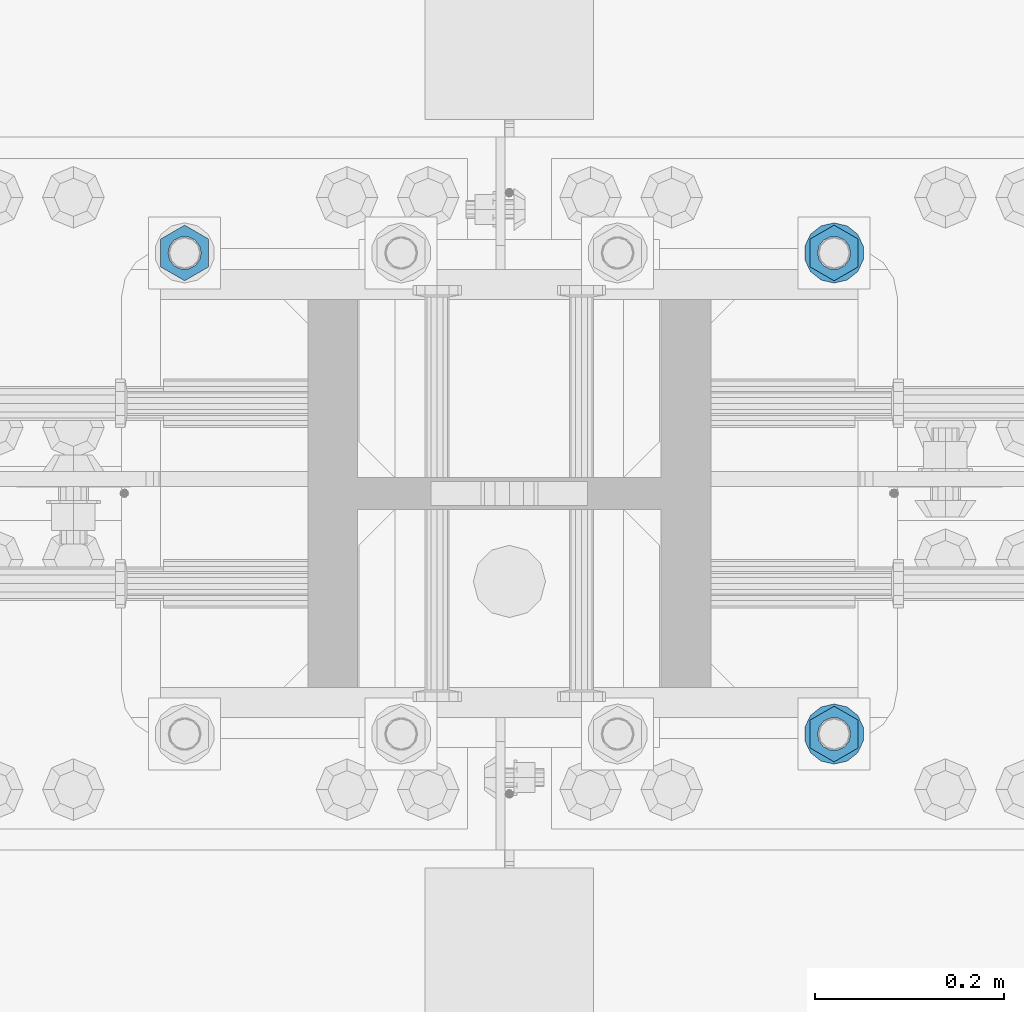
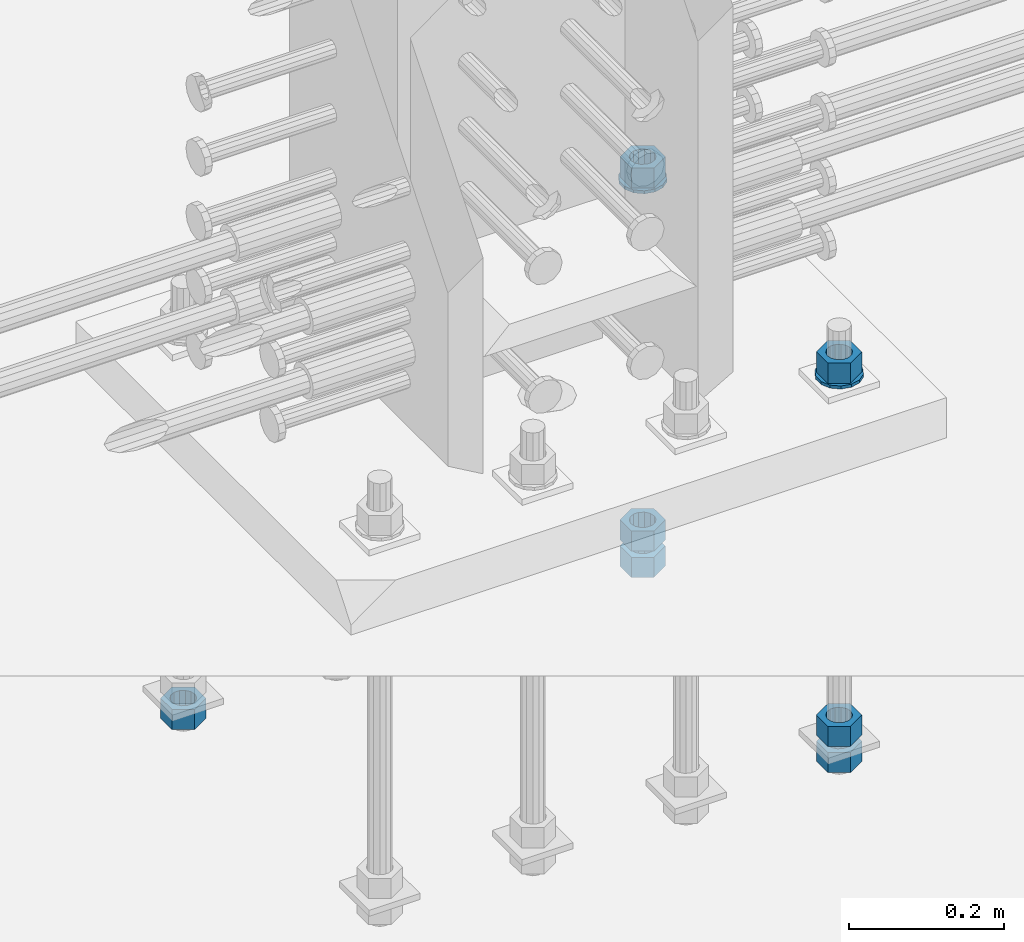
# One storey, part 1002 of 1763: 9 columns, 1 element without a shape of its own.
"""IFC2X3 building model written with IfcOpenShell, lengths in millimetres."""

from ifc_helpers import new_model, si_unit, frame, origin_with_axes, place, context, subcontext, project, spatial, faceted_brep, material, type_object, element, aggregate, save


model = new_model("IFC2X3")

# Units and contexts
model_context = context("Model", 3, precision=1e-05, world=origin_with_axes())
body_context = subcontext(model_context, "Body", "Model", "MODEL_VIEW")
ifc_project = project(units=[si_unit("LENGTHUNIT", "METRE", prefix="MILLI"), si_unit("AREAUNIT", "SQUARE_METRE"), si_unit("VOLUMEUNIT", "CUBIC_METRE"), si_unit("MASSUNIT", "GRAM", prefix="KILO"), si_unit("TIMEUNIT", "SECOND"), si_unit("PLANEANGLEUNIT", "RADIAN"), si_unit("SOLIDANGLEUNIT", "STERADIAN"), si_unit("THERMODYNAMICTEMPERATUREUNIT", "DEGREE_CELSIUS"), si_unit("LUMINOUSINTENSITYUNIT", "LUMEN")], contexts=[model_context])

# Site, building, storey
site_placement = place(None, origin_with_axes())
site = spatial("IfcSite", under=ifc_project, at=site_placement, CompositionType="ELEMENT")
building_placement = place(site_placement, origin_with_axes())
building = spatial("IfcBuilding", under=site, at=building_placement, Name="Undefined", CompositionType="ELEMENT")
storey_placement = place(building_placement, origin_with_axes())
storey = spatial("IfcBuildingStorey", under=building, at=storey_placement, Name="Undefined", CompositionType="ELEMENT", Elevation=0.0)

# Assembly, columns
assembly_placement = place(storey_placement, origin_with_axes())
assembly = element("IfcElementAssembly", 1, at=assembly_placement, inside=storey, Name="TEMPLATE", AssemblyPlace="NOTDEFINED", PredefinedType="RIGID_FRAME")
ifc_material_1 = material(Name="STEEL/A563")
column_type_1 = type_object("IfcColumnType", Name="1-1/4_HEAVY_HEX_NUT", PredefinedType="NOTDEFINED")
column_1_placement = place(assembly_placement, frame((-49059.5372736986, 203.200000000003, 3957.6375), z_axis=(1.0, 0.0, 0.0), x_axis=(0.0, 0.0, -1.0)))
column_1 = element("IfcColumn", 2, at=column_1_placement, type_object=column_type_1, material=ifc_material_1, Name="NUT", ObjectType="1-1/4_HEAVY_HEX_NUT", context=body_context, shape_type="Brep", body=[
    faceted_brep([(0.0, -29.3700008392334, 0.0), (0.0, -14.6800003051758, -25.4300003051758), (31.75, -14.6800003051758, -25.4300003051758), (31.75, -29.3700008392334, 0.0), (0.0, 14.6800003051758, -25.4300003051758), (31.75, 14.6800003051758, -25.4300003051758), (0.0, 29.3700008392334, 0.0), (31.75, 29.3700008392334, 0.0), (0.0, 14.6800003051758, 25.4300003051758), (31.75, 14.6800003051758, 25.4300003051758), (0.0, -14.6800003051758, 25.4300003051758), (31.75, -14.6800003051758, 25.4300003051758), (0.0, 0.0, 17.4599990844727), (0.0, 7.57560968776022, 15.730915608714), (31.75, 7.57560968775942, 15.7309156087145), (31.75, 0.0, 17.4599990844727), (0.0, 13.6507769681037, 10.8861313696252), (31.75, 13.6507769681048, 10.8861313696314), (0.0, 17.0222404541215, 3.88521530314756), (31.75, 17.02224045412, 3.88521530315316), (0.0, 17.0222404541215, -3.88521530314756), (31.75, 17.02224045412, -3.88521530315332), (0.0, 13.6507769681037, -10.8861313696252), (31.75, 13.6507769681048, -10.8861313696316), (0.0, 7.57560968776022, -15.730915608714), (31.75, 7.57560968775942, -15.7309156087146), (0.0, 0.0, -17.4599990844727), (31.75, 0.0, -17.4599990844727), (0.0, -7.57560968776022, -15.730915608714), (31.75, -7.57560968775942, -15.7309156087145), (0.0, -13.6507769681037, -10.8861313696252), (31.75, -13.6507769681048, -10.8861313696314), (0.0, -17.0222404541215, -3.88521530314756), (31.75, -17.02224045412, -3.88521530315316), (0.0, -17.0222404541215, 3.88521530314756), (31.75, -17.02224045412, 3.88521530315332), (0.0, -13.6507769681037, 10.8861313696252), (31.75, -13.6507769681048, 10.8861313696316), (0.0, -7.57560968776022, 15.730915608714), (31.75, -7.57560968775942, 15.7309156087146)], [[[0, 1, 2, 3]], [[1, 4, 5, 2]], [[4, 6, 7, 5]], [[6, 8, 9, 7]], [[8, 10, 11, 9]], [[10, 0, 3, 11]], [[12, 13, 14, 15]], [[13, 16, 17, 14]], [[16, 18, 19, 17]], [[18, 20, 21, 19]], [[20, 22, 23, 21]], [[22, 24, 25, 23]], [[24, 26, 27, 25]], [[26, 28, 29, 27]], [[28, 30, 31, 29]], [[30, 32, 33, 31]], [[32, 34, 35, 33]], [[34, 36, 37, 35]], [[36, 38, 39, 37]], [[38, 12, 15, 39]], [[5, 7, 9, 11, 3, 2], [17, 19, 21, 23, 25, 27, 29, 31, 33, 35, 37, 39, 15, 14]], [[10, 8, 6, 4, 1, 0], [38, 36, 34, 32, 30, 28, 26, 24, 22, 20, 18, 16, 13, 12]]]),
])
column_2_placement = place(assembly_placement, frame((-49059.5372736986, 203.200000000003, 3384.55), z_axis=(1.0, 0.0, 0.0), x_axis=(0.0, 0.0, -1.0)))
column_2 = element("IfcColumn", 3, at=column_2_placement, type_object=column_type_1, material=ifc_material_1, Name="NUT", ObjectType="1-1/4_HEAVY_HEX_NUT", context=body_context, shape_type="Brep", body=[
    faceted_brep([(0.0, -29.3700008392334, 0.0), (0.0, -14.6800003051758, -25.4300003051758), (31.75, -14.6800003051758, -25.4300003051758), (31.75, -29.3700008392334, 0.0), (0.0, 14.6800003051758, -25.4300003051758), (31.75, 14.6800003051758, -25.4300003051758), (0.0, 29.3700008392334, 0.0), (31.75, 29.3700008392334, 0.0), (0.0, 14.6800003051758, 25.4300003051758), (31.75, 14.6800003051758, 25.4300003051758), (0.0, -14.6800003051758, 25.4300003051758), (31.75, -14.6800003051758, 25.4300003051758), (0.0, 0.0, 17.4599990844727), (0.0, 7.57560968776022, 15.730915608714), (31.75, 7.57560968775942, 15.7309156087145), (31.75, 0.0, 17.4599990844727), (0.0, 13.6507769681037, 10.8861313696252), (31.75, 13.6507769681048, 10.8861313696314), (0.0, 17.0222404541215, 3.88521530314756), (31.75, 17.02224045412, 3.88521530315316), (0.0, 17.0222404541215, -3.88521530314756), (31.75, 17.02224045412, -3.88521530315332), (0.0, 13.6507769681037, -10.8861313696252), (31.75, 13.6507769681048, -10.8861313696316), (0.0, 7.57560968776022, -15.730915608714), (31.75, 7.57560968775942, -15.7309156087146), (0.0, 0.0, -17.4599990844727), (31.75, 0.0, -17.4599990844727), (0.0, -7.57560968776022, -15.730915608714), (31.75, -7.57560968775942, -15.7309156087145), (0.0, -13.6507769681037, -10.8861313696252), (31.75, -13.6507769681048, -10.8861313696314), (0.0, -17.0222404541215, -3.88521530314756), (31.75, -17.02224045412, -3.88521530315316), (0.0, -17.0222404541215, 3.88521530314756), (31.75, -17.02224045412, 3.88521530315332), (0.0, -13.6507769681037, 10.8861313696252), (31.75, -13.6507769681048, 10.8861313696316), (0.0, -7.57560968776022, 15.730915608714), (31.75, -7.57560968775942, 15.7309156087146)], [[[0, 1, 2, 3]], [[1, 4, 5, 2]], [[4, 6, 7, 5]], [[6, 8, 9, 7]], [[8, 10, 11, 9]], [[10, 0, 3, 11]], [[12, 13, 14, 15]], [[13, 16, 17, 14]], [[16, 18, 19, 17]], [[18, 20, 21, 19]], [[20, 22, 23, 21]], [[22, 24, 25, 23]], [[24, 26, 27, 25]], [[26, 28, 29, 27]], [[28, 30, 31, 29]], [[30, 32, 33, 31]], [[32, 34, 35, 33]], [[34, 36, 37, 35]], [[36, 38, 39, 37]], [[38, 12, 15, 39]], [[5, 7, 9, 11, 3, 2], [17, 19, 21, 23, 25, 27, 29, 31, 33, 35, 37, 39, 15, 14]], [[10, 8, 6, 4, 1, 0], [38, 36, 34, 32, 30, 28, 26, 24, 22, 20, 18, 16, 13, 12]]]),
])
column_3_placement = place(assembly_placement, frame((-49059.5372736986, 203.200000000003, 3343.275), z_axis=(1.0, 0.0, 0.0), x_axis=(0.0, 0.0, -1.0)))
column_3 = element("IfcColumn", 4, at=column_3_placement, type_object=column_type_1, material=ifc_material_1, Name="NUT", ObjectType="1-1/4_HEAVY_HEX_NUT", context=body_context, shape_type="Brep", body=[
    faceted_brep([(0.0, -29.3700008392334, 0.0), (0.0, -14.6800003051758, -25.4300003051758), (31.75, -14.6800003051758, -25.4300003051758), (31.75, -29.3700008392334, 0.0), (0.0, 14.6800003051758, -25.4300003051758), (31.75, 14.6800003051758, -25.4300003051758), (0.0, 29.3700008392334, 0.0), (31.75, 29.3700008392334, 0.0), (0.0, 14.6800003051758, 25.4300003051758), (31.75, 14.6800003051758, 25.4300003051758), (0.0, -14.6800003051758, 25.4300003051758), (31.75, -14.6800003051758, 25.4300003051758), (0.0, 0.0, 17.4599990844727), (0.0, 7.57560968776022, 15.730915608714), (31.75, 7.57560968775942, 15.7309156087145), (31.75, 0.0, 17.4599990844727), (0.0, 13.6507769681037, 10.8861313696252), (31.75, 13.6507769681048, 10.8861313696314), (0.0, 17.0222404541215, 3.88521530314756), (31.75, 17.02224045412, 3.88521530315316), (0.0, 17.0222404541215, -3.88521530314756), (31.75, 17.02224045412, -3.88521530315332), (0.0, 13.6507769681037, -10.8861313696252), (31.75, 13.6507769681048, -10.8861313696316), (0.0, 7.57560968776022, -15.730915608714), (31.75, 7.57560968775942, -15.7309156087146), (0.0, 0.0, -17.4599990844727), (31.75, 0.0, -17.4599990844727), (0.0, -7.57560968776022, -15.730915608714), (31.75, -7.57560968775942, -15.7309156087145), (0.0, -13.6507769681037, -10.8861313696252), (31.75, -13.6507769681048, -10.8861313696314), (0.0, -17.0222404541215, -3.88521530314756), (31.75, -17.02224045412, -3.88521530315316), (0.0, -17.0222404541215, 3.88521530314756), (31.75, -17.02224045412, 3.88521530315332), (0.0, -13.6507769681037, 10.8861313696252), (31.75, -13.6507769681048, 10.8861313696316), (0.0, -7.57560968776022, 15.730915608714), (31.75, -7.57560968775942, 15.7309156087146)], [[[0, 1, 2, 3]], [[1, 4, 5, 2]], [[4, 6, 7, 5]], [[6, 8, 9, 7]], [[8, 10, 11, 9]], [[10, 0, 3, 11]], [[12, 13, 14, 15]], [[13, 16, 17, 14]], [[16, 18, 19, 17]], [[18, 20, 21, 19]], [[20, 22, 23, 21]], [[22, 24, 25, 23]], [[24, 26, 27, 25]], [[26, 28, 29, 27]], [[28, 30, 31, 29]], [[30, 32, 33, 31]], [[32, 34, 35, 33]], [[34, 36, 37, 35]], [[36, 38, 39, 37]], [[38, 12, 15, 39]], [[5, 7, 9, 11, 3, 2], [17, 19, 21, 23, 25, 27, 29, 31, 33, 35, 37, 39, 15, 14]], [[10, 8, 6, 4, 1, 0], [38, 36, 34, 32, 30, 28, 26, 24, 22, 20, 18, 16, 13, 12]]]),
])
column_4_placement = place(assembly_placement, frame((-49059.5372736986, 711.200000000003, 3957.6375), z_axis=(-1.0, 0.0, 0.0), x_axis=(0.0, 0.0, -1.0)))
column_4 = element("IfcColumn", 5, at=column_4_placement, type_object=column_type_1, material=ifc_material_1, Name="NUT", ObjectType="1-1/4_HEAVY_HEX_NUT", context=body_context, shape_type="Brep", body=[
    faceted_brep([(0.0, -29.3700008392334, 0.0), (0.0, -14.6800003051758, -25.4300003051758), (31.75, -14.6800003051758, -25.4300003051758), (31.75, -29.3700008392334, 0.0), (0.0, 14.6800003051758, -25.4300003051758), (31.75, 14.6800003051758, -25.4300003051758), (0.0, 29.3700008392334, 0.0), (31.75, 29.3700008392334, 0.0), (0.0, 14.6800003051758, 25.4300003051758), (31.75, 14.6800003051758, 25.4300003051758), (0.0, -14.6800003051758, 25.4300003051758), (31.75, -14.6800003051758, 25.4300003051758), (0.0, 0.0, 17.4599990844727), (0.0, 7.57560968776022, 15.730915608714), (31.75, 7.57560968775942, 15.7309156087145), (31.75, 0.0, 17.4599990844727), (0.0, 13.6507769681037, 10.8861313696252), (31.75, 13.6507769681048, 10.8861313696314), (0.0, 17.0222404541215, 3.88521530314756), (31.75, 17.02224045412, 3.88521530315316), (0.0, 17.0222404541215, -3.88521530314756), (31.75, 17.02224045412, -3.88521530315332), (0.0, 13.6507769681037, -10.8861313696252), (31.75, 13.6507769681048, -10.8861313696316), (0.0, 7.57560968776022, -15.730915608714), (31.75, 7.57560968775942, -15.7309156087146), (0.0, 0.0, -17.4599990844727), (31.75, 0.0, -17.4599990844727), (0.0, -7.57560968776022, -15.730915608714), (31.75, -7.57560968775942, -15.7309156087145), (0.0, -13.6507769681037, -10.8861313696252), (31.75, -13.6507769681048, -10.8861313696314), (0.0, -17.0222404541215, -3.88521530314756), (31.75, -17.02224045412, -3.88521530315316), (0.0, -17.0222404541215, 3.88521530314756), (31.75, -17.02224045412, 3.88521530315332), (0.0, -13.6507769681037, 10.8861313696252), (31.75, -13.6507769681048, 10.8861313696316), (0.0, -7.57560968776022, 15.730915608714), (31.75, -7.57560968775942, 15.7309156087146)], [[[0, 1, 2, 3]], [[1, 4, 5, 2]], [[4, 6, 7, 5]], [[6, 8, 9, 7]], [[8, 10, 11, 9]], [[10, 0, 3, 11]], [[12, 13, 14, 15]], [[13, 16, 17, 14]], [[16, 18, 19, 17]], [[18, 20, 21, 19]], [[20, 22, 23, 21]], [[22, 24, 25, 23]], [[24, 26, 27, 25]], [[26, 28, 29, 27]], [[28, 30, 31, 29]], [[30, 32, 33, 31]], [[32, 34, 35, 33]], [[34, 36, 37, 35]], [[36, 38, 39, 37]], [[38, 12, 15, 39]], [[5, 7, 9, 11, 3, 2], [17, 19, 21, 23, 25, 27, 29, 31, 33, 35, 37, 39, 15, 14]], [[10, 8, 6, 4, 1, 0], [38, 36, 34, 32, 30, 28, 26, 24, 22, 20, 18, 16, 13, 12]]]),
])
column_5_placement = place(assembly_placement, frame((-49059.5372736986, 711.200000000003, 3384.55), z_axis=(-1.0, 0.0, 0.0), x_axis=(0.0, 0.0, -1.0)))
column_5 = element("IfcColumn", 6, at=column_5_placement, type_object=column_type_1, material=ifc_material_1, Name="NUT", ObjectType="1-1/4_HEAVY_HEX_NUT", context=body_context, shape_type="Brep", body=[
    faceted_brep([(0.0, -29.3700008392334, 0.0), (0.0, -14.6800003051758, -25.4300003051758), (31.75, -14.6800003051758, -25.4300003051758), (31.75, -29.3700008392334, 0.0), (0.0, 14.6800003051758, -25.4300003051758), (31.75, 14.6800003051758, -25.4300003051758), (0.0, 29.3700008392334, 0.0), (31.75, 29.3700008392334, 0.0), (0.0, 14.6800003051758, 25.4300003051758), (31.75, 14.6800003051758, 25.4300003051758), (0.0, -14.6800003051758, 25.4300003051758), (31.75, -14.6800003051758, 25.4300003051758), (0.0, 0.0, 17.4599990844727), (0.0, 7.57560968776022, 15.730915608714), (31.75, 7.57560968775942, 15.7309156087145), (31.75, 0.0, 17.4599990844727), (0.0, 13.6507769681037, 10.8861313696252), (31.75, 13.6507769681048, 10.8861313696314), (0.0, 17.0222404541215, 3.88521530314756), (31.75, 17.02224045412, 3.88521530315316), (0.0, 17.0222404541215, -3.88521530314756), (31.75, 17.02224045412, -3.88521530315332), (0.0, 13.6507769681037, -10.8861313696252), (31.75, 13.6507769681048, -10.8861313696316), (0.0, 7.57560968776022, -15.730915608714), (31.75, 7.57560968775942, -15.7309156087146), (0.0, 0.0, -17.4599990844727), (31.75, 0.0, -17.4599990844727), (0.0, -7.57560968776022, -15.730915608714), (31.75, -7.57560968775942, -15.7309156087145), (0.0, -13.6507769681037, -10.8861313696252), (31.75, -13.6507769681048, -10.8861313696314), (0.0, -17.0222404541215, -3.88521530314756), (31.75, -17.02224045412, -3.88521530315316), (0.0, -17.0222404541215, 3.88521530314756), (31.75, -17.02224045412, 3.88521530315332), (0.0, -13.6507769681037, 10.8861313696252), (31.75, -13.6507769681048, 10.8861313696316), (0.0, -7.57560968776022, 15.730915608714), (31.75, -7.57560968775942, 15.7309156087146)], [[[0, 1, 2, 3]], [[1, 4, 5, 2]], [[4, 6, 7, 5]], [[6, 8, 9, 7]], [[8, 10, 11, 9]], [[10, 0, 3, 11]], [[12, 13, 14, 15]], [[13, 16, 17, 14]], [[16, 18, 19, 17]], [[18, 20, 21, 19]], [[20, 22, 23, 21]], [[22, 24, 25, 23]], [[24, 26, 27, 25]], [[26, 28, 29, 27]], [[28, 30, 31, 29]], [[30, 32, 33, 31]], [[32, 34, 35, 33]], [[34, 36, 37, 35]], [[36, 38, 39, 37]], [[38, 12, 15, 39]], [[5, 7, 9, 11, 3, 2], [17, 19, 21, 23, 25, 27, 29, 31, 33, 35, 37, 39, 15, 14]], [[10, 8, 6, 4, 1, 0], [38, 36, 34, 32, 30, 28, 26, 24, 22, 20, 18, 16, 13, 12]]]),
])
column_6_placement = place(assembly_placement, frame((-49059.5372736986, 711.200000000003, 3343.275), z_axis=(-1.0, 0.0, 0.0), x_axis=(0.0, 0.0, -1.0)))
column_6 = element("IfcColumn", 7, at=column_6_placement, type_object=column_type_1, material=ifc_material_1, Name="NUT", ObjectType="1-1/4_HEAVY_HEX_NUT", context=body_context, shape_type="Brep", body=[
    faceted_brep([(0.0, -29.3700008392334, 0.0), (0.0, -14.6800003051758, -25.4300003051758), (31.75, -14.6800003051758, -25.4300003051758), (31.75, -29.3700008392334, 0.0), (0.0, 14.6800003051758, -25.4300003051758), (31.75, 14.6800003051758, -25.4300003051758), (0.0, 29.3700008392334, 0.0), (31.75, 29.3700008392334, 0.0), (0.0, 14.6800003051758, 25.4300003051758), (31.75, 14.6800003051758, 25.4300003051758), (0.0, -14.6800003051758, 25.4300003051758), (31.75, -14.6800003051758, 25.4300003051758), (0.0, 0.0, 17.4599990844727), (0.0, 7.57560968776022, 15.730915608714), (31.75, 7.57560968775942, 15.7309156087145), (31.75, 0.0, 17.4599990844727), (0.0, 13.6507769681037, 10.8861313696252), (31.75, 13.6507769681048, 10.8861313696314), (0.0, 17.0222404541215, 3.88521530314756), (31.75, 17.02224045412, 3.88521530315316), (0.0, 17.0222404541215, -3.88521530314756), (31.75, 17.02224045412, -3.88521530315332), (0.0, 13.6507769681037, -10.8861313696252), (31.75, 13.6507769681048, -10.8861313696316), (0.0, 7.57560968776022, -15.730915608714), (31.75, 7.57560968775942, -15.7309156087146), (0.0, 0.0, -17.4599990844727), (31.75, 0.0, -17.4599990844727), (0.0, -7.57560968776022, -15.730915608714), (31.75, -7.57560968775942, -15.7309156087145), (0.0, -13.6507769681037, -10.8861313696252), (31.75, -13.6507769681048, -10.8861313696314), (0.0, -17.0222404541215, -3.88521530314756), (31.75, -17.02224045412, -3.88521530315316), (0.0, -17.0222404541215, 3.88521530314756), (31.75, -17.02224045412, 3.88521530315332), (0.0, -13.6507769681037, 10.8861313696252), (31.75, -13.6507769681048, 10.8861313696316), (0.0, -7.57560968776022, 15.730915608714), (31.75, -7.57560968775942, 15.7309156087146)], [[[0, 1, 2, 3]], [[1, 4, 5, 2]], [[4, 6, 7, 5]], [[6, 8, 9, 7]], [[8, 10, 11, 9]], [[10, 0, 3, 11]], [[12, 13, 14, 15]], [[13, 16, 17, 14]], [[16, 18, 19, 17]], [[18, 20, 21, 19]], [[20, 22, 23, 21]], [[22, 24, 25, 23]], [[24, 26, 27, 25]], [[26, 28, 29, 27]], [[28, 30, 31, 29]], [[30, 32, 33, 31]], [[32, 34, 35, 33]], [[34, 36, 37, 35]], [[36, 38, 39, 37]], [[38, 12, 15, 39]], [[5, 7, 9, 11, 3, 2], [17, 19, 21, 23, 25, 27, 29, 31, 33, 35, 37, 39, 15, 14]], [[10, 8, 6, 4, 1, 0], [38, 36, 34, 32, 30, 28, 26, 24, 22, 20, 18, 16, 13, 12]]]),
])
column_7_placement = place(assembly_placement, frame((-49745.3372736986, 711.200000000003, 3343.275), z_axis=(-1.0, 0.0, 0.0), x_axis=(0.0, 0.0, -1.0)))
column_7 = element("IfcColumn", 8, at=column_7_placement, type_object=column_type_1, material=ifc_material_1, Name="NUT", ObjectType="1-1/4_HEAVY_HEX_NUT", context=body_context, shape_type="Brep", body=[
    faceted_brep([(0.0, -29.3700008392334, 0.0), (0.0, -14.6800003051758, -25.4300003051758), (31.75, -14.6800003051758, -25.4300003051758), (31.75, -29.3700008392334, 0.0), (0.0, 14.6800003051758, -25.4300003051758), (31.75, 14.6800003051758, -25.4300003051758), (0.0, 29.3700008392334, 0.0), (31.75, 29.3700008392334, 0.0), (0.0, 14.6800003051758, 25.4300003051758), (31.75, 14.6800003051758, 25.4300003051758), (0.0, -14.6800003051758, 25.4300003051758), (31.75, -14.6800003051758, 25.4300003051758), (0.0, 0.0, 17.4599990844727), (0.0, 7.57560968776022, 15.730915608714), (31.75, 7.57560968775942, 15.7309156087145), (31.75, 0.0, 17.4599990844727), (0.0, 13.6507769681037, 10.8861313696252), (31.75, 13.6507769681048, 10.8861313696314), (0.0, 17.0222404541215, 3.88521530314756), (31.75, 17.02224045412, 3.88521530315316), (0.0, 17.0222404541215, -3.88521530314756), (31.75, 17.02224045412, -3.88521530315332), (0.0, 13.6507769681037, -10.8861313696252), (31.75, 13.6507769681048, -10.8861313696316), (0.0, 7.57560968776022, -15.730915608714), (31.75, 7.57560968775942, -15.7309156087146), (0.0, 0.0, -17.4599990844727), (31.75, 0.0, -17.4599990844727), (0.0, -7.57560968776022, -15.730915608714), (31.75, -7.57560968775942, -15.7309156087145), (0.0, -13.6507769681037, -10.8861313696252), (31.75, -13.6507769681048, -10.8861313696314), (0.0, -17.0222404541215, -3.88521530314756), (31.75, -17.02224045412, -3.88521530315316), (0.0, -17.0222404541215, 3.88521530314756), (31.75, -17.02224045412, 3.88521530315332), (0.0, -13.6507769681037, 10.8861313696252), (31.75, -13.6507769681048, 10.8861313696316), (0.0, -7.57560968776022, 15.730915608714), (31.75, -7.57560968775942, 15.7309156087146)], [[[0, 1, 2, 3]], [[1, 4, 5, 2]], [[4, 6, 7, 5]], [[6, 8, 9, 7]], [[8, 10, 11, 9]], [[10, 0, 3, 11]], [[12, 13, 14, 15]], [[13, 16, 17, 14]], [[16, 18, 19, 17]], [[18, 20, 21, 19]], [[20, 22, 23, 21]], [[22, 24, 25, 23]], [[24, 26, 27, 25]], [[26, 28, 29, 27]], [[28, 30, 31, 29]], [[30, 32, 33, 31]], [[32, 34, 35, 33]], [[34, 36, 37, 35]], [[36, 38, 39, 37]], [[38, 12, 15, 39]], [[5, 7, 9, 11, 3, 2], [17, 19, 21, 23, 25, 27, 29, 31, 33, 35, 37, 39, 15, 14]], [[10, 8, 6, 4, 1, 0], [38, 36, 34, 32, 30, 28, 26, 24, 22, 20, 18, 16, 13, 12]]]),
])
ifc_material_2 = material(Name="STEEL/F436")
column_type_2 = type_object("IfcColumnType", Name="1-1/4_WASHER", PredefinedType="NOTDEFINED")
column_8_placement = place(assembly_placement, frame((-49059.5372736986, 203.200000000003, 3925.8875), z_axis=(1.0, 0.0, 0.0), x_axis=(0.0, 0.0, -1.0)))
column_8 = element("IfcColumn", 9, at=column_8_placement, type_object=column_type_2, material=ifc_material_2, Name="WASHER", ObjectType="1-1/4_WASHER", context=body_context, shape_type="Brep", body=[
    faceted_brep([(-4.54747350886464e-13, -31.7499999999964, 0.0), (0.0, -28.6057615559002, -13.7758087169827), (4.76249999999982, -28.6057615559002, -13.7758087169827), (4.76249999999982, -31.75, 0.0), (0.0, -19.795801209013, -24.8231495683602), (4.76249999999982, -19.795801209013, -24.8231495683602), (0.0, -7.06503965311276, -30.9539612117732), (4.76249999999982, -7.06503965311276, -30.9539612117732), (0.0, 7.06503965311276, -30.9539612117732), (4.76249999999982, 7.06503965311276, -30.9539612117732), (0.0, 19.7958012090166, -24.8231495683602), (4.76249999999982, 19.7958012090166, -24.8231495683602), (0.0, 28.6057615559039, -13.7758087169827), (4.76249999999982, 28.6057615559039, -13.7758087169827), (-5.91171556152403e-12, 31.7499999999891, 0.0), (4.76249999999982, 31.75, 0.0), (0.0, 28.6057615559002, 13.7758087169827), (4.76249999999982, 28.6057615559002, 13.7758087169827), (0.0, 19.795801209013, 24.8231495683602), (4.76249999999982, 19.795801209013, 24.8231495683602), (0.0, 7.06503965311276, 30.9539612117731), (4.76249999999982, 7.06503965311276, 30.9539612117731), (0.0, -7.06503965311276, 30.9539612117731), (4.76249999999982, -7.06503965311276, 30.9539612117731), (0.0, -19.7958012090166, 24.8231495683602), (4.76249999999982, -19.7958012090166, 24.8231495683602), (0.0, -28.6057615559039, 13.7758087169827), (4.76249999999982, -28.6057615559039, 13.7758087169827), (0.0, 0.0, 17.4599990844727), (0.0, 7.57560968776022, 15.730915608714), (4.76249999999982, 7.57560968775942, 15.7309156087145), (4.76249999999982, 0.0, 17.4599990844727), (0.0, 13.6507769681037, 10.8861313696252), (4.76249999999982, 13.6507769681048, 10.8861313696314), (0.0, 17.0222404541215, 3.88521530314756), (4.76249999999982, 17.02224045412, 3.88521530315316), (0.0, 17.0222404541215, -3.88521530314756), (4.76249999999982, 17.02224045412, -3.88521530315332), (0.0, 13.6507769681037, -10.8861313696252), (4.76249999999982, 13.6507769681048, -10.8861313696316), (0.0, 7.57560968776022, -15.730915608714), (4.76249999999982, 7.57560968775942, -15.7309156087146), (0.0, 0.0, -17.4599990844727), (4.76249999999982, 0.0, -17.4599990844727), (0.0, -7.57560968776022, -15.730915608714), (4.76249999999982, -7.57560968775942, -15.7309156087145), (0.0, -13.6507769681037, -10.8861313696252), (4.76249999999982, -13.6507769681048, -10.8861313696314), (0.0, -17.0222404541215, -3.88521530314756), (4.76249999999982, -17.02224045412, -3.88521530315316), (0.0, -17.0222404541215, 3.88521530314756), (4.76249999999982, -17.02224045412, 3.88521530315332), (0.0, -13.6507769681037, 10.8861313696252), (4.76249999999982, -13.6507769681048, 10.8861313696316), (0.0, -7.57560968776022, 15.730915608714), (4.76249999999982, -7.57560968775942, 15.7309156087146)], [[[0, 1, 2, 3]], [[1, 4, 5, 2]], [[4, 6, 7, 5]], [[6, 8, 9, 7]], [[8, 10, 11, 9]], [[10, 12, 13, 11]], [[12, 14, 15, 13]], [[14, 16, 17, 15]], [[16, 18, 19, 17]], [[18, 20, 21, 19]], [[20, 22, 23, 21]], [[22, 24, 25, 23]], [[24, 26, 27, 25]], [[26, 0, 3, 27]], [[28, 29, 30, 31]], [[29, 32, 33, 30]], [[32, 34, 35, 33]], [[34, 36, 37, 35]], [[36, 38, 39, 37]], [[38, 40, 41, 39]], [[40, 42, 43, 41]], [[42, 44, 45, 43]], [[44, 46, 47, 45]], [[46, 48, 49, 47]], [[48, 50, 51, 49]], [[50, 52, 53, 51]], [[52, 54, 55, 53]], [[54, 28, 31, 55]], [[5, 7, 9, 11, 13, 15, 17, 19, 21, 23, 25, 27, 3, 2], [33, 35, 37, 39, 41, 43, 45, 47, 49, 51, 53, 55, 31, 30]], [[26, 24, 22, 20, 18, 16, 14, 12, 10, 8, 6, 4, 1, 0], [54, 52, 50, 48, 46, 44, 42, 40, 38, 36, 34, 32, 29, 28]]]),
])
column_9_placement = place(assembly_placement, frame((-49059.5372736986, 711.200000000003, 3925.8875), z_axis=(-1.0, 0.0, 0.0), x_axis=(0.0, 0.0, -1.0)))
column_9 = element("IfcColumn", 10, at=column_9_placement, type_object=column_type_2, material=ifc_material_2, Name="WASHER", ObjectType="1-1/4_WASHER", context=body_context, shape_type="Brep", body=[
    faceted_brep([(-4.54747350886464e-13, -31.7499999999964, 0.0), (0.0, -28.6057615559002, -13.7758087169827), (4.76249999999982, -28.6057615559002, -13.7758087169827), (4.76249999999982, -31.75, 0.0), (0.0, -19.795801209013, -24.8231495683602), (4.76249999999982, -19.795801209013, -24.8231495683602), (0.0, -7.06503965311276, -30.9539612117732), (4.76249999999982, -7.06503965311276, -30.9539612117732), (0.0, 7.06503965311276, -30.9539612117732), (4.76249999999982, 7.06503965311276, -30.9539612117732), (0.0, 19.7958012090166, -24.8231495683602), (4.76249999999982, 19.7958012090166, -24.8231495683602), (0.0, 28.6057615559039, -13.7758087169827), (4.76249999999982, 28.6057615559039, -13.7758087169827), (-5.91171556152403e-12, 31.7499999999891, 0.0), (4.76249999999982, 31.75, 0.0), (0.0, 28.6057615559002, 13.7758087169827), (4.76249999999982, 28.6057615559002, 13.7758087169827), (0.0, 19.795801209013, 24.8231495683602), (4.76249999999982, 19.795801209013, 24.8231495683602), (0.0, 7.06503965311276, 30.9539612117731), (4.76249999999982, 7.06503965311276, 30.9539612117731), (0.0, -7.06503965311276, 30.9539612117731), (4.76249999999982, -7.06503965311276, 30.9539612117731), (0.0, -19.7958012090166, 24.8231495683602), (4.76249999999982, -19.7958012090166, 24.8231495683602), (0.0, -28.6057615559039, 13.7758087169827), (4.76249999999982, -28.6057615559039, 13.7758087169827), (0.0, 0.0, 17.4599990844727), (0.0, 7.57560968776022, 15.730915608714), (4.76249999999982, 7.57560968775942, 15.7309156087145), (4.76249999999982, 0.0, 17.4599990844727), (0.0, 13.6507769681037, 10.8861313696252), (4.76249999999982, 13.6507769681048, 10.8861313696314), (0.0, 17.0222404541215, 3.88521530314756), (4.76249999999982, 17.02224045412, 3.88521530315316), (0.0, 17.0222404541215, -3.88521530314756), (4.76249999999982, 17.02224045412, -3.88521530315332), (0.0, 13.6507769681037, -10.8861313696252), (4.76249999999982, 13.6507769681048, -10.8861313696316), (0.0, 7.57560968776022, -15.730915608714), (4.76249999999982, 7.57560968775942, -15.7309156087146), (0.0, 0.0, -17.4599990844727), (4.76249999999982, 0.0, -17.4599990844727), (0.0, -7.57560968776022, -15.730915608714), (4.76249999999982, -7.57560968775942, -15.7309156087145), (0.0, -13.6507769681037, -10.8861313696252), (4.76249999999982, -13.6507769681048, -10.8861313696314), (0.0, -17.0222404541215, -3.88521530314756), (4.76249999999982, -17.02224045412, -3.88521530315316), (0.0, -17.0222404541215, 3.88521530314756), (4.76249999999982, -17.02224045412, 3.88521530315332), (0.0, -13.6507769681037, 10.8861313696252), (4.76249999999982, -13.6507769681048, 10.8861313696316), (0.0, -7.57560968776022, 15.730915608714), (4.76249999999982, -7.57560968775942, 15.7309156087146)], [[[0, 1, 2, 3]], [[1, 4, 5, 2]], [[4, 6, 7, 5]], [[6, 8, 9, 7]], [[8, 10, 11, 9]], [[10, 12, 13, 11]], [[12, 14, 15, 13]], [[14, 16, 17, 15]], [[16, 18, 19, 17]], [[18, 20, 21, 19]], [[20, 22, 23, 21]], [[22, 24, 25, 23]], [[24, 26, 27, 25]], [[26, 0, 3, 27]], [[28, 29, 30, 31]], [[29, 32, 33, 30]], [[32, 34, 35, 33]], [[34, 36, 37, 35]], [[36, 38, 39, 37]], [[38, 40, 41, 39]], [[40, 42, 43, 41]], [[42, 44, 45, 43]], [[44, 46, 47, 45]], [[46, 48, 49, 47]], [[48, 50, 51, 49]], [[50, 52, 53, 51]], [[52, 54, 55, 53]], [[54, 28, 31, 55]], [[5, 7, 9, 11, 13, 15, 17, 19, 21, 23, 25, 27, 3, 2], [33, 35, 37, 39, 41, 43, 45, 47, 49, 51, 53, 55, 31, 30]], [[26, 24, 22, 20, 18, 16, 14, 12, 10, 8, 6, 4, 1, 0], [54, 52, 50, 48, 46, 44, 42, 40, 38, 36, 34, 32, 29, 28]]]),
])
aggregate(assembly, [column_1, column_8, column_2, column_3, column_4, column_9, column_5, column_6, column_7])

save(model, "model.ifc")
